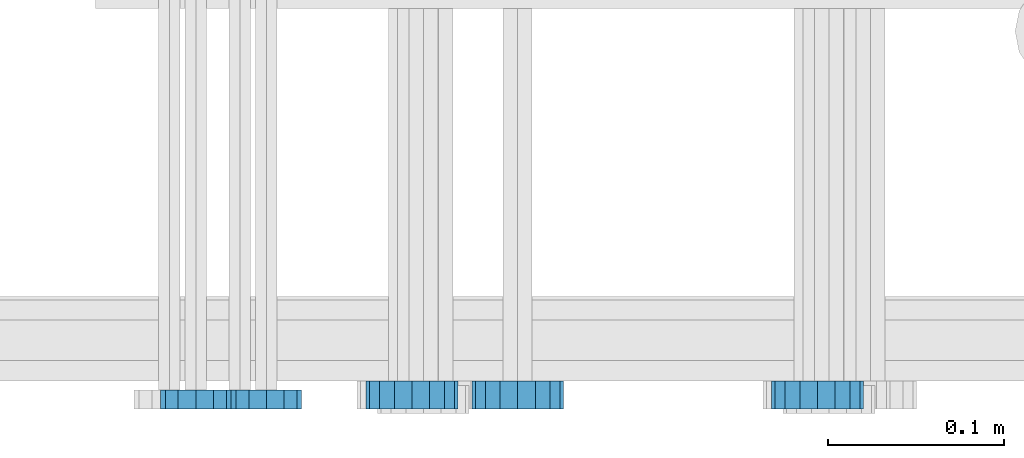
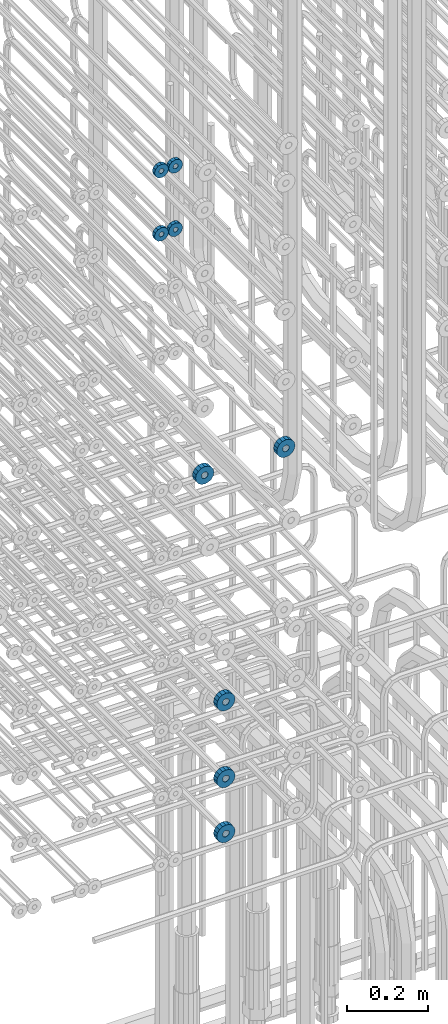
# One storey, part 166 of 177: 9 beams.
"""IFC2X3 building model written with IfcOpenShell, lengths in millimetres."""

from ifc_helpers import new_model, si_unit, frame, origin_with_axes, place, context, subcontext, project, spatial, faceted_brep, material, type_object, element, save


model = new_model("IFC2X3")

# Units and contexts
model_context_1 = context("Model", 3, precision=1e-05, world=origin_with_axes())
model_context_2 = context("Model", 3, precision=1e-05, world=origin_with_axes())
body_context = subcontext(model_context_2, "Body", "Model", "MODEL_VIEW")
ifc_project = project(units=[si_unit("LENGTHUNIT", "METRE", prefix="MILLI"), si_unit("AREAUNIT", "SQUARE_METRE"), si_unit("VOLUMEUNIT", "CUBIC_METRE"), si_unit("MASSUNIT", "GRAM", prefix="KILO"), si_unit("TIMEUNIT", "SECOND"), si_unit("PLANEANGLEUNIT", "RADIAN"), si_unit("SOLIDANGLEUNIT", "STERADIAN"), si_unit("THERMODYNAMICTEMPERATUREUNIT", "DEGREE_CELSIUS"), si_unit("LUMINOUSINTENSITYUNIT", "LUMEN")], contexts=[model_context_1])

# Site, building, storey
site_placement = place(None, origin_with_axes())
site = spatial("IfcSite", under=ifc_project, at=site_placement, CompositionType="ELEMENT")
building_placement = place(site_placement, origin_with_axes())
building = spatial("IfcBuilding", under=site, at=building_placement, Name="Undefined", CompositionType="ELEMENT")
storey_placement = place(building_placement, origin_with_axes())
storey = spatial("IfcBuildingStorey", under=building, at=storey_placement, Name="Undefined", CompositionType="ELEMENT", Elevation=0.0)

# Beams
ifc_material = material(Name="STEEL/Steel_Undefined")
beam_type_1 = type_object("IfcBeamType", PredefinedType="NOTDEFINED")
beam_1_placement = place(storey_placement, frame((2036046.99847313, 6205070.98588031, 22304.9868114254), z_axis=(0.0, 0.0, -1.0), x_axis=(0.0, -1.0, 0.0)))
element("IfcBeam", 1, at=beam_1_placement, inside=storey, type_object=beam_type_1, material=ifc_material, context=body_context, shape_type="Brep", body=[
    faceted_brep([(-3.63797880709171e-12, -7.0, -2.3283064365387e-10), (-8.62348444298797e-13, -6.06217782649107, 3.5), (10.9999999999964, -6.06217782665044, 3.49999999976717), (10.9999999999964, -7.0, -2.3283064365387e-10), (-3.63797880709171e-12, -3.5, 6.06217782618478), (11.0, -3.5, 6.06217782618478), (-1.72469688859759e-12, 0.0, 7.0), (11.0, 0.0, 6.99999999976717), (-3.63797880709171e-12, 3.5, 6.06217782618478), (11.0, 3.5, 6.06217782618478), (-8.62348444298795e-13, 6.06217782649107, 3.5), (10.9999999999964, 6.06217782665044, 3.49999999976717), (-3.63797880709171e-12, 7.0, -2.3283064365387e-10), (10.9999999999964, 7.0, -2.3283064365387e-10), (8.62348444298797e-13, 6.06217782649107, -3.5), (10.9999999999964, 6.06217782665044, -3.50000000023283), (-3.63797880709171e-12, 3.5, -6.06217782665044), (10.9999999999964, 3.5, -6.06217782665044), (1.72469688859759e-12, -2.72004641033163e-15, -7.0), (10.9999999999964, 0.0, -7.00000000023283), (-3.63797880709171e-12, -3.5, -6.06217782665044), (10.9999999999964, -3.5, -6.06217782665044), (8.62348444298796e-13, -6.06217782649107, -3.5), (10.9999999999964, -6.06217782665044, -3.50000000023283), (0.0, -20.0000000009313, 0.0), (0.0, -17.320508075878, -10.0), (10.9999999999964, -17.320508075878, -10.0000000002328), (10.9999999999964, -20.0, -2.3283064365387e-10), (0.0, -10.0000000009313, -17.3205080756452), (11.0, -10.0, -17.320508075878), (0.0, -1.86264514923096e-09, -19.9999999998836), (10.9999999999964, 0.0, -20.0000000002328), (0.0, 9.99999999906868, -17.3205080755288), (11.0, 10.0, -17.320508075878), (0.0, 17.320508075878, -10.0), (10.9999999999964, 17.320508075878, -10.0000000002328), (0.0, 19.9999999990687, 0.0), (10.9999999999964, 20.0, -2.3283064365387e-10), (0.0, 17.3205080740154, 10.0), (11.0, 17.320508075878, 9.99999999976717), (0.0, 9.99999999906868, 17.3205080757616), (10.9999999999964, 10.0, 17.3205080754124), (0.0, 0.0, 20.0000000001164), (10.9999999999964, 0.0, 19.9999999997672), (0.0, -10.0000000009313, 17.3205080757616), (10.9999999999964, -10.0, 17.3205080754124), (0.0, -17.3205080777407, 10.0000000001164), (11.0, -17.320508075878, 9.99999999976717)], [[[0, 1, 2, 3]], [[1, 4, 5, 2]], [[4, 6, 7, 5]], [[6, 8, 9, 7]], [[8, 10, 11, 9]], [[10, 12, 13, 11]], [[12, 14, 15, 13]], [[14, 16, 17, 15]], [[16, 18, 19, 17]], [[18, 20, 21, 19]], [[20, 22, 23, 21]], [[22, 0, 3, 23]], [[24, 25, 26, 27]], [[25, 28, 29, 26]], [[28, 30, 31, 29]], [[30, 32, 33, 31]], [[32, 34, 35, 33]], [[34, 36, 37, 35]], [[36, 38, 39, 37]], [[38, 40, 41, 39]], [[40, 42, 43, 41]], [[42, 44, 45, 43]], [[44, 46, 47, 45]], [[46, 24, 27, 47]], [[29, 31, 33, 35, 37, 39, 41, 43, 45, 47, 27, 26], [5, 7, 9, 11, 13, 15, 17, 19, 21, 23, 3, 2]], [[46, 44, 42, 40, 38, 36, 34, 32, 30, 28, 25, 24], [22, 20, 18, 16, 14, 12, 10, 8, 6, 4, 1, 0]]]),
])
beam_2_placement = place(storey_placement, frame((2036006.99847313, 6205070.98588031, 22304.9868114254), z_axis=(0.0, 0.0, -1.0), x_axis=(0.0, -1.0, 0.0)))
element("IfcBeam", 2, at=beam_2_placement, inside=storey, type_object=beam_type_1, material=ifc_material, context=body_context, shape_type="Brep", body=[
    faceted_brep([(-3.63797880709171e-12, -7.0, -2.3283064365387e-10), (-8.62348444298797e-13, -6.06217782649107, 3.5), (10.9999999999964, -6.06217782665044, 3.49999999976717), (10.9999999999964, -7.0, -2.3283064365387e-10), (-3.63797880709171e-12, -3.5, 6.06217782618478), (11.0, -3.5, 6.06217782618478), (-1.72469688859759e-12, 0.0, 7.0), (11.0, 0.0, 6.99999999976717), (-3.63797880709171e-12, 3.5, 6.06217782618478), (11.0, 3.5, 6.06217782618478), (-8.62348444298795e-13, 6.06217782649107, 3.5), (10.9999999999964, 6.06217782665044, 3.49999999976717), (-3.63797880709171e-12, 7.0, -2.3283064365387e-10), (10.9999999999964, 7.0, -2.3283064365387e-10), (8.62348444298797e-13, 6.06217782649107, -3.5), (10.9999999999964, 6.06217782665044, -3.50000000023283), (-3.63797880709171e-12, 3.5, -6.06217782665044), (10.9999999999964, 3.5, -6.06217782665044), (1.72469688859759e-12, -2.72004641033163e-15, -7.0), (10.9999999999964, 0.0, -7.00000000023283), (-3.63797880709171e-12, -3.5, -6.06217782665044), (10.9999999999964, -3.5, -6.06217782665044), (8.62348444298796e-13, -6.06217782649107, -3.5), (10.9999999999964, -6.06217782665044, -3.50000000023283), (0.0, -20.0000000009313, 0.0), (0.0, -17.320508075878, -10.0), (10.9999999999964, -17.320508075878, -10.0000000002328), (10.9999999999964, -20.0, -2.3283064365387e-10), (0.0, -10.0000000009313, -17.3205080756452), (11.0, -10.0, -17.320508075878), (0.0, -1.86264514923096e-09, -19.9999999998836), (10.9999999999964, 0.0, -20.0000000002328), (0.0, 9.99999999906868, -17.3205080755288), (11.0, 10.0, -17.320508075878), (0.0, 17.320508075878, -10.0), (10.9999999999964, 17.320508075878, -10.0000000002328), (0.0, 19.9999999990687, 0.0), (10.9999999999964, 20.0, -2.3283064365387e-10), (0.0, 17.3205080740154, 10.0), (11.0, 17.320508075878, 9.99999999976717), (0.0, 9.99999999906868, 17.3205080757616), (10.9999999999964, 10.0, 17.3205080754124), (0.0, 0.0, 20.0000000001164), (10.9999999999964, 0.0, 19.9999999997672), (0.0, -10.0000000009313, 17.3205080757616), (10.9999999999964, -10.0, 17.3205080754124), (0.0, -17.3205080777407, 10.0000000001164), (11.0, -17.320508075878, 9.99999999976717)], [[[0, 1, 2, 3]], [[1, 4, 5, 2]], [[4, 6, 7, 5]], [[6, 8, 9, 7]], [[8, 10, 11, 9]], [[10, 12, 13, 11]], [[12, 14, 15, 13]], [[14, 16, 17, 15]], [[16, 18, 19, 17]], [[18, 20, 21, 19]], [[20, 22, 23, 21]], [[22, 0, 3, 23]], [[24, 25, 26, 27]], [[25, 28, 29, 26]], [[28, 30, 31, 29]], [[30, 32, 33, 31]], [[32, 34, 35, 33]], [[34, 36, 37, 35]], [[36, 38, 39, 37]], [[38, 40, 41, 39]], [[40, 42, 43, 41]], [[42, 44, 45, 43]], [[44, 46, 47, 45]], [[46, 24, 27, 47]], [[29, 31, 33, 35, 37, 39, 41, 43, 45, 47, 27, 26], [5, 7, 9, 11, 13, 15, 17, 19, 21, 23, 3, 2]], [[46, 44, 42, 40, 38, 36, 34, 32, 30, 28, 25, 24], [22, 20, 18, 16, 14, 12, 10, 8, 6, 4, 1, 0]]]),
])
beam_3_placement = place(storey_placement, frame((2036046.99847313, 6205070.98588032, 22114.9868114254), z_axis=(0.0, 0.0, -1.0), x_axis=(0.0, -1.0, 0.0)))
element("IfcBeam", 3, at=beam_3_placement, inside=storey, type_object=beam_type_1, material=ifc_material, context=body_context, shape_type="Brep", body=[
    faceted_brep([(-3.63797880709171e-12, -7.0, -2.3283064365387e-10), (-8.62348444298797e-13, -6.06217782649107, 3.5), (10.9999999999964, -6.06217782665044, 3.49999999976717), (10.9999999999964, -7.0, -2.3283064365387e-10), (-3.63797880709171e-12, -3.5, 6.06217782618478), (11.0, -3.5, 6.06217782618478), (-1.72469688859759e-12, 0.0, 7.0), (11.0, 0.0, 6.99999999976717), (-3.63797880709171e-12, 3.5, 6.06217782618478), (11.0, 3.5, 6.06217782618478), (-8.62348444298795e-13, 6.06217782649107, 3.5), (10.9999999999964, 6.06217782665044, 3.49999999976717), (-3.63797880709171e-12, 7.0, -2.3283064365387e-10), (10.9999999999964, 7.0, -2.3283064365387e-10), (8.62348444298797e-13, 6.06217782649107, -3.5), (10.9999999999964, 6.06217782665044, -3.50000000023283), (-3.63797880709171e-12, 3.5, -6.06217782665044), (10.9999999999964, 3.5, -6.06217782665044), (1.72469688859759e-12, -2.72004641033163e-15, -7.0), (10.9999999999964, 0.0, -7.00000000023283), (-3.63797880709171e-12, -3.5, -6.06217782665044), (10.9999999999964, -3.5, -6.06217782665044), (8.62348444298796e-13, -6.06217782649107, -3.5), (10.9999999999964, -6.06217782665044, -3.50000000023283), (0.0, -20.0000000009313, 0.0), (0.0, -17.320508075878, -10.0), (10.9999999999964, -17.320508075878, -10.0000000002328), (10.9999999999964, -20.0, -2.3283064365387e-10), (0.0, -10.0000000009313, -17.3205080756452), (11.0, -10.0, -17.320508075878), (0.0, -1.86264514923096e-09, -19.9999999998836), (10.9999999999964, 0.0, -20.0000000002328), (0.0, 9.99999999906868, -17.3205080755288), (11.0, 10.0, -17.320508075878), (0.0, 17.320508075878, -10.0), (10.9999999999964, 17.320508075878, -10.0000000002328), (0.0, 19.9999999990687, 0.0), (10.9999999999964, 20.0, -2.3283064365387e-10), (0.0, 17.3205080740154, 10.0), (11.0, 17.320508075878, 9.99999999976717), (0.0, 9.99999999906868, 17.3205080757616), (10.9999999999964, 10.0, 17.3205080754124), (0.0, 0.0, 20.0000000001164), (10.9999999999964, 0.0, 19.9999999997672), (0.0, -10.0000000009313, 17.3205080757616), (10.9999999999964, -10.0, 17.3205080754124), (0.0, -17.3205080777407, 10.0000000001164), (11.0, -17.320508075878, 9.99999999976717)], [[[0, 1, 2, 3]], [[1, 4, 5, 2]], [[4, 6, 7, 5]], [[6, 8, 9, 7]], [[8, 10, 11, 9]], [[10, 12, 13, 11]], [[12, 14, 15, 13]], [[14, 16, 17, 15]], [[16, 18, 19, 17]], [[18, 20, 21, 19]], [[20, 22, 23, 21]], [[22, 0, 3, 23]], [[24, 25, 26, 27]], [[25, 28, 29, 26]], [[28, 30, 31, 29]], [[30, 32, 33, 31]], [[32, 34, 35, 33]], [[34, 36, 37, 35]], [[36, 38, 39, 37]], [[38, 40, 41, 39]], [[40, 42, 43, 41]], [[42, 44, 45, 43]], [[44, 46, 47, 45]], [[46, 24, 27, 47]], [[29, 31, 33, 35, 37, 39, 41, 43, 45, 47, 27, 26], [5, 7, 9, 11, 13, 15, 17, 19, 21, 23, 3, 2]], [[46, 44, 42, 40, 38, 36, 34, 32, 30, 28, 25, 24], [22, 20, 18, 16, 14, 12, 10, 8, 6, 4, 1, 0]]]),
])
beam_4_placement = place(storey_placement, frame((2036006.99847313, 6205070.98588032, 22114.9868114254), z_axis=(0.0, 0.0, -1.0), x_axis=(0.0, -1.0, 0.0)))
element("IfcBeam", 4, at=beam_4_placement, inside=storey, type_object=beam_type_1, material=ifc_material, context=body_context, shape_type="Brep", body=[
    faceted_brep([(-3.63797880709171e-12, -7.0, -2.3283064365387e-10), (-8.62348444298797e-13, -6.06217782649107, 3.5), (10.9999999999964, -6.06217782665044, 3.49999999976717), (10.9999999999964, -7.0, -2.3283064365387e-10), (-3.63797880709171e-12, -3.5, 6.06217782618478), (11.0, -3.5, 6.06217782618478), (-1.72469688859759e-12, 0.0, 7.0), (11.0, 0.0, 6.99999999976717), (-3.63797880709171e-12, 3.5, 6.06217782618478), (11.0, 3.5, 6.06217782618478), (-8.62348444298795e-13, 6.06217782649107, 3.5), (10.9999999999964, 6.06217782665044, 3.49999999976717), (-3.63797880709171e-12, 7.0, -2.3283064365387e-10), (10.9999999999964, 7.0, -2.3283064365387e-10), (8.62348444298797e-13, 6.06217782649107, -3.5), (10.9999999999964, 6.06217782665044, -3.50000000023283), (-3.63797880709171e-12, 3.5, -6.06217782665044), (10.9999999999964, 3.5, -6.06217782665044), (1.72469688859759e-12, -2.72004641033163e-15, -7.0), (10.9999999999964, 0.0, -7.00000000023283), (-3.63797880709171e-12, -3.5, -6.06217782665044), (10.9999999999964, -3.5, -6.06217782665044), (8.62348444298796e-13, -6.06217782649107, -3.5), (10.9999999999964, -6.06217782665044, -3.50000000023283), (0.0, -20.0000000009313, 0.0), (0.0, -17.320508075878, -10.0), (10.9999999999964, -17.320508075878, -10.0000000002328), (10.9999999999964, -20.0, -2.3283064365387e-10), (0.0, -10.0000000009313, -17.3205080756452), (11.0, -10.0, -17.320508075878), (0.0, -1.86264514923096e-09, -19.9999999998836), (10.9999999999964, 0.0, -20.0000000002328), (0.0, 9.99999999906868, -17.3205080755288), (11.0, 10.0, -17.320508075878), (0.0, 17.320508075878, -10.0), (10.9999999999964, 17.320508075878, -10.0000000002328), (0.0, 19.9999999990687, 0.0), (10.9999999999964, 20.0, -2.3283064365387e-10), (0.0, 17.3205080740154, 10.0), (11.0, 17.320508075878, 9.99999999976717), (0.0, 9.99999999906868, 17.3205080757616), (10.9999999999964, 10.0, 17.3205080754124), (0.0, 0.0, 20.0000000001164), (10.9999999999964, 0.0, 19.9999999997672), (0.0, -10.0000000009313, 17.3205080757616), (10.9999999999964, -10.0, 17.3205080754124), (0.0, -17.3205080777407, 10.0000000001164), (11.0, -17.320508075878, 9.99999999976717)], [[[0, 1, 2, 3]], [[1, 4, 5, 2]], [[4, 6, 7, 5]], [[6, 8, 9, 7]], [[8, 10, 11, 9]], [[10, 12, 13, 11]], [[12, 14, 15, 13]], [[14, 16, 17, 15]], [[16, 18, 19, 17]], [[18, 20, 21, 19]], [[20, 22, 23, 21]], [[22, 0, 3, 23]], [[24, 25, 26, 27]], [[25, 28, 29, 26]], [[28, 30, 31, 29]], [[30, 32, 33, 31]], [[32, 34, 35, 33]], [[34, 36, 37, 35]], [[36, 38, 39, 37]], [[38, 40, 41, 39]], [[40, 42, 43, 41]], [[42, 44, 45, 43]], [[44, 46, 47, 45]], [[46, 24, 27, 47]], [[29, 31, 33, 35, 37, 39, 41, 43, 45, 47, 27, 26], [5, 7, 9, 11, 13, 15, 17, 19, 21, 23, 3, 2]], [[46, 44, 42, 40, 38, 36, 34, 32, 30, 28, 25, 24], [22, 20, 18, 16, 14, 12, 10, 8, 6, 4, 1, 0]]]),
])
beam_type_2 = type_object("IfcBeamType", PredefinedType="NOTDEFINED")
beam_5_placement = place(storey_placement, frame((2036359.49847313, 6205075.98588576, 21349.9868126719), z_axis=(0.0, 0.0, -1.0), x_axis=(0.0, -1.0, 0.0)))
element("IfcBeam", 5, at=beam_5_placement, inside=storey, type_object=beam_type_2, material=ifc_material, context=body_context, shape_type="Brep", body=[
    faceted_brep([(0.0, -9.5, 0.0), (0.0, -8.77685555908829, 3.63549260746731), (16.0, -8.77685555908829, 3.63549260746731), (16.0, -9.5, 0.0), (0.0, -6.71751442085952, 6.71751442127061), (16.0, -6.71751442085952, 6.71751442127061), (0.0, -3.63549260701984, 8.77685555885546), (16.0, -3.63549260701984, 8.77685555885546), (-2.02452244836415e-12, 0.0, 9.5), (16.0, 0.0, 9.5), (0.0, 3.63549260701984, 8.77685555885546), (16.0, 3.63549260701984, 8.77685555885546), (0.0, 6.71751442085952, 6.71751442127061), (16.0, 6.71751442085952, 6.71751442127061), (0.0, 8.77685555908829, 3.63549260746731), (16.0, 8.77685555908829, 3.63549260746731), (0.0, 9.5, 0.0), (16.0, 9.5, 0.0), (0.0, 8.77685555908829, -3.63549260746731), (16.0, 8.77685555908829, -3.63549260746731), (0.0, 6.71751442085952, -6.71751442127061), (16.0, 6.71751442085952, -6.71751442127061), (0.0, 3.63549260701984, -8.77685555885546), (16.0, 3.63549260701984, -8.77685555885546), (2.02452244836415e-12, -3.69149155687865e-15, -9.5), (16.0, 0.0, -9.5), (0.0, -3.63549260701984, -8.77685555885546), (16.0, -3.63549260701984, -8.77685555885546), (0.0, -6.71751442085952, -6.71751442127061), (16.0, -6.71751442085952, -6.71751442127061), (0.0, -8.77685555908829, -3.63549260746731), (16.0, -8.77685555908829, -3.63549260746731), (0.0, -26.0, 0.0), (0.0, -24.0208678450435, -9.94976924149159), (16.0, -24.0208678450435, -9.94976924149159), (16.0, -26.0, 0.0), (0.0, -18.3847763109952, -18.3847763108497), (16.0, -18.3847763109952, -18.3847763108497), (0.0, -9.94976924173534, -24.0208678452946), (16.0, -9.94976924173534, -24.0208678452946), (0.0, 0.0, -26.0), (16.0, 0.0, -26.0), (0.0, 9.94976924173534, -24.0208678452946), (16.0, 9.94976924173534, -24.0208678452946), (0.0, 18.3847763109952, -18.3847763108497), (16.0, 18.3847763109952, -18.3847763108497), (0.0, 24.0208678450435, -9.94976924149159), (16.0, 24.0208678450435, -9.94976924149159), (0.0, 26.0, 0.0), (16.0, 26.0, 0.0), (0.0, 24.0208678450435, 9.94976924149159), (16.0, 24.0208678450435, 9.94976924149159), (0.0, 18.3847763109952, 18.3847763108497), (16.0, 18.3847763109952, 18.3847763108497), (0.0, 9.94976924173534, 24.0208678452946), (16.0, 9.94976924173534, 24.0208678452946), (0.0, 0.0, 26.0), (16.0, 0.0, 26.0), (0.0, -9.94976924173534, 24.0208678452946), (16.0, -9.94976924173534, 24.0208678452946), (0.0, -18.3847763109952, 18.3847763108497), (16.0, -18.3847763109952, 18.3847763108497), (0.0, -24.0208678450435, 9.94976924149159), (16.0, -24.0208678450435, 9.94976924149159)], [[[0, 1, 2, 3]], [[1, 4, 5, 2]], [[4, 6, 7, 5]], [[6, 8, 9, 7]], [[8, 10, 11, 9]], [[10, 12, 13, 11]], [[12, 14, 15, 13]], [[14, 16, 17, 15]], [[16, 18, 19, 17]], [[18, 20, 21, 19]], [[20, 22, 23, 21]], [[22, 24, 25, 23]], [[24, 26, 27, 25]], [[26, 28, 29, 27]], [[28, 30, 31, 29]], [[30, 0, 3, 31]], [[32, 33, 34, 35]], [[33, 36, 37, 34]], [[36, 38, 39, 37]], [[38, 40, 41, 39]], [[40, 42, 43, 41]], [[42, 44, 45, 43]], [[44, 46, 47, 45]], [[46, 48, 49, 47]], [[48, 50, 51, 49]], [[50, 52, 53, 51]], [[52, 54, 55, 53]], [[54, 56, 57, 55]], [[56, 58, 59, 57]], [[58, 60, 61, 59]], [[60, 62, 63, 61]], [[62, 32, 35, 63]], [[37, 39, 41, 43, 45, 47, 49, 51, 53, 55, 57, 59, 61, 63, 35, 34], [5, 7, 9, 11, 13, 15, 17, 19, 21, 23, 25, 27, 29, 31, 3, 2]], [[62, 60, 58, 56, 54, 52, 50, 48, 46, 44, 42, 40, 38, 36, 33, 32], [30, 28, 26, 24, 22, 20, 18, 16, 14, 12, 10, 8, 6, 4, 1, 0]]]),
])
beam_6_placement = place(storey_placement, frame((2036129.49847313, 6205075.98588576, 21349.9868126719), z_axis=(0.0, 0.0, -1.0), x_axis=(0.0, -1.0, 0.0)))
element("IfcBeam", 6, at=beam_6_placement, inside=storey, type_object=beam_type_2, material=ifc_material, context=body_context, shape_type="Brep", body=[
    faceted_brep([(0.0, -9.5, 0.0), (0.0, -8.77685555908829, 3.63549260746731), (16.0, -8.77685555908829, 3.63549260746731), (16.0, -9.5, 0.0), (0.0, -6.71751442085952, 6.71751442127061), (16.0, -6.71751442085952, 6.71751442127061), (0.0, -3.63549260701984, 8.77685555885546), (16.0, -3.63549260701984, 8.77685555885546), (-2.02452244836415e-12, 0.0, 9.5), (16.0, 0.0, 9.5), (0.0, 3.63549260701984, 8.77685555885546), (16.0, 3.63549260701984, 8.77685555885546), (0.0, 6.71751442085952, 6.71751442127061), (16.0, 6.71751442085952, 6.71751442127061), (0.0, 8.77685555908829, 3.63549260746731), (16.0, 8.77685555908829, 3.63549260746731), (0.0, 9.5, 0.0), (16.0, 9.5, 0.0), (0.0, 8.77685555908829, -3.63549260746731), (16.0, 8.77685555908829, -3.63549260746731), (0.0, 6.71751442085952, -6.71751442127061), (16.0, 6.71751442085952, -6.71751442127061), (0.0, 3.63549260701984, -8.77685555885546), (16.0, 3.63549260701984, -8.77685555885546), (2.02452244836415e-12, -3.69149155687865e-15, -9.5), (16.0, 0.0, -9.5), (0.0, -3.63549260701984, -8.77685555885546), (16.0, -3.63549260701984, -8.77685555885546), (0.0, -6.71751442085952, -6.71751442127061), (16.0, -6.71751442085952, -6.71751442127061), (0.0, -8.77685555908829, -3.63549260746731), (16.0, -8.77685555908829, -3.63549260746731), (0.0, -26.0, 0.0), (0.0, -24.0208678450435, -9.94976924149159), (16.0, -24.0208678450435, -9.94976924149159), (16.0, -26.0, 0.0), (0.0, -18.3847763109952, -18.3847763108497), (16.0, -18.3847763109952, -18.3847763108497), (0.0, -9.94976924173534, -24.0208678452946), (16.0, -9.94976924173534, -24.0208678452946), (0.0, 0.0, -26.0), (16.0, 0.0, -26.0), (0.0, 9.94976924173534, -24.0208678452946), (16.0, 9.94976924173534, -24.0208678452946), (0.0, 18.3847763109952, -18.3847763108497), (16.0, 18.3847763109952, -18.3847763108497), (0.0, 24.0208678450435, -9.94976924149159), (16.0, 24.0208678450435, -9.94976924149159), (0.0, 26.0, 0.0), (16.0, 26.0, 0.0), (0.0, 24.0208678450435, 9.94976924149159), (16.0, 24.0208678450435, 9.94976924149159), (0.0, 18.3847763109952, 18.3847763108497), (16.0, 18.3847763109952, 18.3847763108497), (0.0, 9.94976924173534, 24.0208678452946), (16.0, 9.94976924173534, 24.0208678452946), (0.0, 0.0, 26.0), (16.0, 0.0, 26.0), (0.0, -9.94976924173534, 24.0208678452946), (16.0, -9.94976924173534, 24.0208678452946), (0.0, -18.3847763109952, 18.3847763108497), (16.0, -18.3847763109952, 18.3847763108497), (0.0, -24.0208678450435, 9.94976924149159), (16.0, -24.0208678450435, 9.94976924149159)], [[[0, 1, 2, 3]], [[1, 4, 5, 2]], [[4, 6, 7, 5]], [[6, 8, 9, 7]], [[8, 10, 11, 9]], [[10, 12, 13, 11]], [[12, 14, 15, 13]], [[14, 16, 17, 15]], [[16, 18, 19, 17]], [[18, 20, 21, 19]], [[20, 22, 23, 21]], [[22, 24, 25, 23]], [[24, 26, 27, 25]], [[26, 28, 29, 27]], [[28, 30, 31, 29]], [[30, 0, 3, 31]], [[32, 33, 34, 35]], [[33, 36, 37, 34]], [[36, 38, 39, 37]], [[38, 40, 41, 39]], [[40, 42, 43, 41]], [[42, 44, 45, 43]], [[44, 46, 47, 45]], [[46, 48, 49, 47]], [[48, 50, 51, 49]], [[50, 52, 53, 51]], [[52, 54, 55, 53]], [[54, 56, 57, 55]], [[56, 58, 59, 57]], [[58, 60, 61, 59]], [[60, 62, 63, 61]], [[62, 32, 35, 63]], [[37, 39, 41, 43, 45, 47, 49, 51, 53, 55, 57, 59, 61, 63, 35, 34], [5, 7, 9, 11, 13, 15, 17, 19, 21, 23, 25, 27, 29, 31, 3, 2]], [[62, 60, 58, 56, 54, 52, 50, 48, 46, 44, 42, 40, 38, 36, 33, 32], [30, 28, 26, 24, 22, 20, 18, 16, 14, 12, 10, 8, 6, 4, 1, 0]]]),
])
beam_7_placement = place(storey_placement, frame((2036189.49847313, 6205075.98588034, 20649.9868114201), z_axis=(0.0, 0.0, -1.0), x_axis=(0.0, -1.0, 0.0)))
element("IfcBeam", 7, at=beam_7_placement, inside=storey, type_object=beam_type_2, material=ifc_material, context=body_context, shape_type="Brep", body=[
    faceted_brep([(0.0, -9.5, 0.0), (0.0, -8.77685555908829, 3.63549260746731), (16.0, -8.77685555908829, 3.63549260746731), (16.0, -9.5, 0.0), (0.0, -6.71751442085952, 6.71751442127061), (16.0, -6.71751442085952, 6.71751442127061), (0.0, -3.63549260701984, 8.77685555885546), (16.0, -3.63549260701984, 8.77685555885546), (-2.02452244836415e-12, 0.0, 9.5), (16.0, 0.0, 9.5), (0.0, 3.63549260701984, 8.77685555885546), (16.0, 3.63549260701984, 8.77685555885546), (0.0, 6.71751442085952, 6.71751442127061), (16.0, 6.71751442085952, 6.71751442127061), (0.0, 8.77685555908829, 3.63549260746731), (16.0, 8.77685555908829, 3.63549260746731), (0.0, 9.5, 0.0), (16.0, 9.5, 0.0), (0.0, 8.77685555908829, -3.63549260746731), (16.0, 8.77685555908829, -3.63549260746731), (0.0, 6.71751442085952, -6.71751442127061), (16.0, 6.71751442085952, -6.71751442127061), (0.0, 3.63549260701984, -8.77685555885546), (16.0, 3.63549260701984, -8.77685555885546), (2.02452244836415e-12, -3.69149155687865e-15, -9.5), (16.0, 0.0, -9.5), (0.0, -3.63549260701984, -8.77685555885546), (16.0, -3.63549260701984, -8.77685555885546), (0.0, -6.71751442085952, -6.71751442127061), (16.0, -6.71751442085952, -6.71751442127061), (0.0, -8.77685555908829, -3.63549260746731), (16.0, -8.77685555908829, -3.63549260746731), (0.0, -26.0, 0.0), (0.0, -24.0208678450435, -9.94976924149159), (16.0, -24.0208678450435, -9.94976924149159), (16.0, -26.0, 0.0), (0.0, -18.3847763109952, -18.3847763108497), (16.0, -18.3847763109952, -18.3847763108497), (0.0, -9.94976924173534, -24.0208678452946), (16.0, -9.94976924173534, -24.0208678452946), (0.0, 0.0, -26.0), (16.0, 0.0, -26.0), (0.0, 9.94976924173534, -24.0208678452946), (16.0, 9.94976924173534, -24.0208678452946), (0.0, 18.3847763109952, -18.3847763108497), (16.0, 18.3847763109952, -18.3847763108497), (0.0, 24.0208678450435, -9.94976924149159), (16.0, 24.0208678450435, -9.94976924149159), (0.0, 26.0, 0.0), (16.0, 26.0, 0.0), (0.0, 24.0208678450435, 9.94976924149159), (16.0, 24.0208678450435, 9.94976924149159), (0.0, 18.3847763109952, 18.3847763108497), (16.0, 18.3847763109952, 18.3847763108497), (0.0, 9.94976924173534, 24.0208678452946), (16.0, 9.94976924173534, 24.0208678452946), (0.0, 0.0, 26.0), (16.0, 0.0, 26.0), (0.0, -9.94976924173534, 24.0208678452946), (16.0, -9.94976924173534, 24.0208678452946), (0.0, -18.3847763109952, 18.3847763108497), (16.0, -18.3847763109952, 18.3847763108497), (0.0, -24.0208678450435, 9.94976924149159), (16.0, -24.0208678450435, 9.94976924149159)], [[[0, 1, 2, 3]], [[1, 4, 5, 2]], [[4, 6, 7, 5]], [[6, 8, 9, 7]], [[8, 10, 11, 9]], [[10, 12, 13, 11]], [[12, 14, 15, 13]], [[14, 16, 17, 15]], [[16, 18, 19, 17]], [[18, 20, 21, 19]], [[20, 22, 23, 21]], [[22, 24, 25, 23]], [[24, 26, 27, 25]], [[26, 28, 29, 27]], [[28, 30, 31, 29]], [[30, 0, 3, 31]], [[32, 33, 34, 35]], [[33, 36, 37, 34]], [[36, 38, 39, 37]], [[38, 40, 41, 39]], [[40, 42, 43, 41]], [[42, 44, 45, 43]], [[44, 46, 47, 45]], [[46, 48, 49, 47]], [[48, 50, 51, 49]], [[50, 52, 53, 51]], [[52, 54, 55, 53]], [[54, 56, 57, 55]], [[56, 58, 59, 57]], [[58, 60, 61, 59]], [[60, 62, 63, 61]], [[62, 32, 35, 63]], [[37, 39, 41, 43, 45, 47, 49, 51, 53, 55, 57, 59, 61, 63, 35, 34], [5, 7, 9, 11, 13, 15, 17, 19, 21, 23, 25, 27, 29, 31, 3, 2]], [[62, 60, 58, 56, 54, 52, 50, 48, 46, 44, 42, 40, 38, 36, 33, 32], [30, 28, 26, 24, 22, 20, 18, 16, 14, 12, 10, 8, 6, 4, 1, 0]]]),
])
beam_8_placement = place(storey_placement, frame((2036189.49847313, 6205075.98588034, 20419.9868114201), z_axis=(0.0, 0.0, -1.0), x_axis=(0.0, -1.0, 0.0)))
element("IfcBeam", 8, at=beam_8_placement, inside=storey, type_object=beam_type_2, material=ifc_material, context=body_context, shape_type="Brep", body=[
    faceted_brep([(0.0, -9.5, 0.0), (0.0, -8.77685555908829, 3.63549260746731), (16.0, -8.77685555908829, 3.63549260746731), (16.0, -9.5, 0.0), (0.0, -6.71751442085952, 6.71751442127061), (16.0, -6.71751442085952, 6.71751442127061), (0.0, -3.63549260701984, 8.77685555885546), (16.0, -3.63549260701984, 8.77685555885546), (-2.02452244836415e-12, 0.0, 9.5), (16.0, 0.0, 9.5), (0.0, 3.63549260701984, 8.77685555885546), (16.0, 3.63549260701984, 8.77685555885546), (0.0, 6.71751442085952, 6.71751442127061), (16.0, 6.71751442085952, 6.71751442127061), (0.0, 8.77685555908829, 3.63549260746731), (16.0, 8.77685555908829, 3.63549260746731), (0.0, 9.5, 0.0), (16.0, 9.5, 0.0), (0.0, 8.77685555908829, -3.63549260746731), (16.0, 8.77685555908829, -3.63549260746731), (0.0, 6.71751442085952, -6.71751442127061), (16.0, 6.71751442085952, -6.71751442127061), (0.0, 3.63549260701984, -8.77685555885546), (16.0, 3.63549260701984, -8.77685555885546), (2.02452244836415e-12, -3.69149155687865e-15, -9.5), (16.0, 0.0, -9.5), (0.0, -3.63549260701984, -8.77685555885546), (16.0, -3.63549260701984, -8.77685555885546), (0.0, -6.71751442085952, -6.71751442127061), (16.0, -6.71751442085952, -6.71751442127061), (0.0, -8.77685555908829, -3.63549260746731), (16.0, -8.77685555908829, -3.63549260746731), (0.0, -26.0, 0.0), (0.0, -24.0208678450435, -9.94976924149159), (16.0, -24.0208678450435, -9.94976924149159), (16.0, -26.0, 0.0), (0.0, -18.3847763109952, -18.3847763108497), (16.0, -18.3847763109952, -18.3847763108497), (0.0, -9.94976924173534, -24.0208678452946), (16.0, -9.94976924173534, -24.0208678452946), (0.0, 0.0, -26.0), (16.0, 0.0, -26.0), (0.0, 9.94976924173534, -24.0208678452946), (16.0, 9.94976924173534, -24.0208678452946), (0.0, 18.3847763109952, -18.3847763108497), (16.0, 18.3847763109952, -18.3847763108497), (0.0, 24.0208678450435, -9.94976924149159), (16.0, 24.0208678450435, -9.94976924149159), (0.0, 26.0, 0.0), (16.0, 26.0, 0.0), (0.0, 24.0208678450435, 9.94976924149159), (16.0, 24.0208678450435, 9.94976924149159), (0.0, 18.3847763109952, 18.3847763108497), (16.0, 18.3847763109952, 18.3847763108497), (0.0, 9.94976924173534, 24.0208678452946), (16.0, 9.94976924173534, 24.0208678452946), (0.0, 0.0, 26.0), (16.0, 0.0, 26.0), (0.0, -9.94976924173534, 24.0208678452946), (16.0, -9.94976924173534, 24.0208678452946), (0.0, -18.3847763109952, 18.3847763108497), (16.0, -18.3847763109952, 18.3847763108497), (0.0, -24.0208678450435, 9.94976924149159), (16.0, -24.0208678450435, 9.94976924149159)], [[[0, 1, 2, 3]], [[1, 4, 5, 2]], [[4, 6, 7, 5]], [[6, 8, 9, 7]], [[8, 10, 11, 9]], [[10, 12, 13, 11]], [[12, 14, 15, 13]], [[14, 16, 17, 15]], [[16, 18, 19, 17]], [[18, 20, 21, 19]], [[20, 22, 23, 21]], [[22, 24, 25, 23]], [[24, 26, 27, 25]], [[26, 28, 29, 27]], [[28, 30, 31, 29]], [[30, 0, 3, 31]], [[32, 33, 34, 35]], [[33, 36, 37, 34]], [[36, 38, 39, 37]], [[38, 40, 41, 39]], [[40, 42, 43, 41]], [[42, 44, 45, 43]], [[44, 46, 47, 45]], [[46, 48, 49, 47]], [[48, 50, 51, 49]], [[50, 52, 53, 51]], [[52, 54, 55, 53]], [[54, 56, 57, 55]], [[56, 58, 59, 57]], [[58, 60, 61, 59]], [[60, 62, 63, 61]], [[62, 32, 35, 63]], [[37, 39, 41, 43, 45, 47, 49, 51, 53, 55, 57, 59, 61, 63, 35, 34], [5, 7, 9, 11, 13, 15, 17, 19, 21, 23, 25, 27, 29, 31, 3, 2]], [[62, 60, 58, 56, 54, 52, 50, 48, 46, 44, 42, 40, 38, 36, 33, 32], [30, 28, 26, 24, 22, 20, 18, 16, 14, 12, 10, 8, 6, 4, 1, 0]]]),
])
beam_9_placement = place(storey_placement, frame((2036189.49847313, 6205075.98588034, 20254.9868114201), z_axis=(0.0, 0.0, -1.0), x_axis=(0.0, -1.0, 0.0)))
element("IfcBeam", 9, at=beam_9_placement, inside=storey, type_object=beam_type_2, material=ifc_material, context=body_context, shape_type="Brep", body=[
    faceted_brep([(0.0, -9.5, 0.0), (0.0, -8.77685555908829, 3.63549260746731), (16.0, -8.77685555908829, 3.63549260746731), (16.0, -9.5, 0.0), (0.0, -6.71751442085952, 6.71751442127061), (16.0, -6.71751442085952, 6.71751442127061), (0.0, -3.63549260701984, 8.77685555885546), (16.0, -3.63549260701984, 8.77685555885546), (-2.02452244836415e-12, 0.0, 9.5), (16.0, 0.0, 9.5), (0.0, 3.63549260701984, 8.77685555885546), (16.0, 3.63549260701984, 8.77685555885546), (0.0, 6.71751442085952, 6.71751442127061), (16.0, 6.71751442085952, 6.71751442127061), (0.0, 8.77685555908829, 3.63549260746731), (16.0, 8.77685555908829, 3.63549260746731), (0.0, 9.5, 0.0), (16.0, 9.5, 0.0), (0.0, 8.77685555908829, -3.63549260746731), (16.0, 8.77685555908829, -3.63549260746731), (0.0, 6.71751442085952, -6.71751442127061), (16.0, 6.71751442085952, -6.71751442127061), (0.0, 3.63549260701984, -8.77685555885546), (16.0, 3.63549260701984, -8.77685555885546), (2.02452244836415e-12, -3.69149155687865e-15, -9.5), (16.0, 0.0, -9.5), (0.0, -3.63549260701984, -8.77685555885546), (16.0, -3.63549260701984, -8.77685555885546), (0.0, -6.71751442085952, -6.71751442127061), (16.0, -6.71751442085952, -6.71751442127061), (0.0, -8.77685555908829, -3.63549260746731), (16.0, -8.77685555908829, -3.63549260746731), (0.0, -26.0, 0.0), (0.0, -24.0208678450435, -9.94976924149159), (16.0, -24.0208678450435, -9.94976924149159), (16.0, -26.0, 0.0), (0.0, -18.3847763109952, -18.3847763108497), (16.0, -18.3847763109952, -18.3847763108497), (0.0, -9.94976924173534, -24.0208678452946), (16.0, -9.94976924173534, -24.0208678452946), (0.0, 0.0, -26.0), (16.0, 0.0, -26.0), (0.0, 9.94976924173534, -24.0208678452946), (16.0, 9.94976924173534, -24.0208678452946), (0.0, 18.3847763109952, -18.3847763108497), (16.0, 18.3847763109952, -18.3847763108497), (0.0, 24.0208678450435, -9.94976924149159), (16.0, 24.0208678450435, -9.94976924149159), (0.0, 26.0, 0.0), (16.0, 26.0, 0.0), (0.0, 24.0208678450435, 9.94976924149159), (16.0, 24.0208678450435, 9.94976924149159), (0.0, 18.3847763109952, 18.3847763108497), (16.0, 18.3847763109952, 18.3847763108497), (0.0, 9.94976924173534, 24.0208678452946), (16.0, 9.94976924173534, 24.0208678452946), (0.0, 0.0, 26.0), (16.0, 0.0, 26.0), (0.0, -9.94976924173534, 24.0208678452946), (16.0, -9.94976924173534, 24.0208678452946), (0.0, -18.3847763109952, 18.3847763108497), (16.0, -18.3847763109952, 18.3847763108497), (0.0, -24.0208678450435, 9.94976924149159), (16.0, -24.0208678450435, 9.94976924149159)], [[[0, 1, 2, 3]], [[1, 4, 5, 2]], [[4, 6, 7, 5]], [[6, 8, 9, 7]], [[8, 10, 11, 9]], [[10, 12, 13, 11]], [[12, 14, 15, 13]], [[14, 16, 17, 15]], [[16, 18, 19, 17]], [[18, 20, 21, 19]], [[20, 22, 23, 21]], [[22, 24, 25, 23]], [[24, 26, 27, 25]], [[26, 28, 29, 27]], [[28, 30, 31, 29]], [[30, 0, 3, 31]], [[32, 33, 34, 35]], [[33, 36, 37, 34]], [[36, 38, 39, 37]], [[38, 40, 41, 39]], [[40, 42, 43, 41]], [[42, 44, 45, 43]], [[44, 46, 47, 45]], [[46, 48, 49, 47]], [[48, 50, 51, 49]], [[50, 52, 53, 51]], [[52, 54, 55, 53]], [[54, 56, 57, 55]], [[56, 58, 59, 57]], [[58, 60, 61, 59]], [[60, 62, 63, 61]], [[62, 32, 35, 63]], [[37, 39, 41, 43, 45, 47, 49, 51, 53, 55, 57, 59, 61, 63, 35, 34], [5, 7, 9, 11, 13, 15, 17, 19, 21, 23, 25, 27, 29, 31, 3, 2]], [[62, 60, 58, 56, 54, 52, 50, 48, 46, 44, 42, 40, 38, 36, 33, 32], [30, 28, 26, 24, 22, 20, 18, 16, 14, 12, 10, 8, 6, 4, 1, 0]]]),
])

save(model, "model.ifc")
